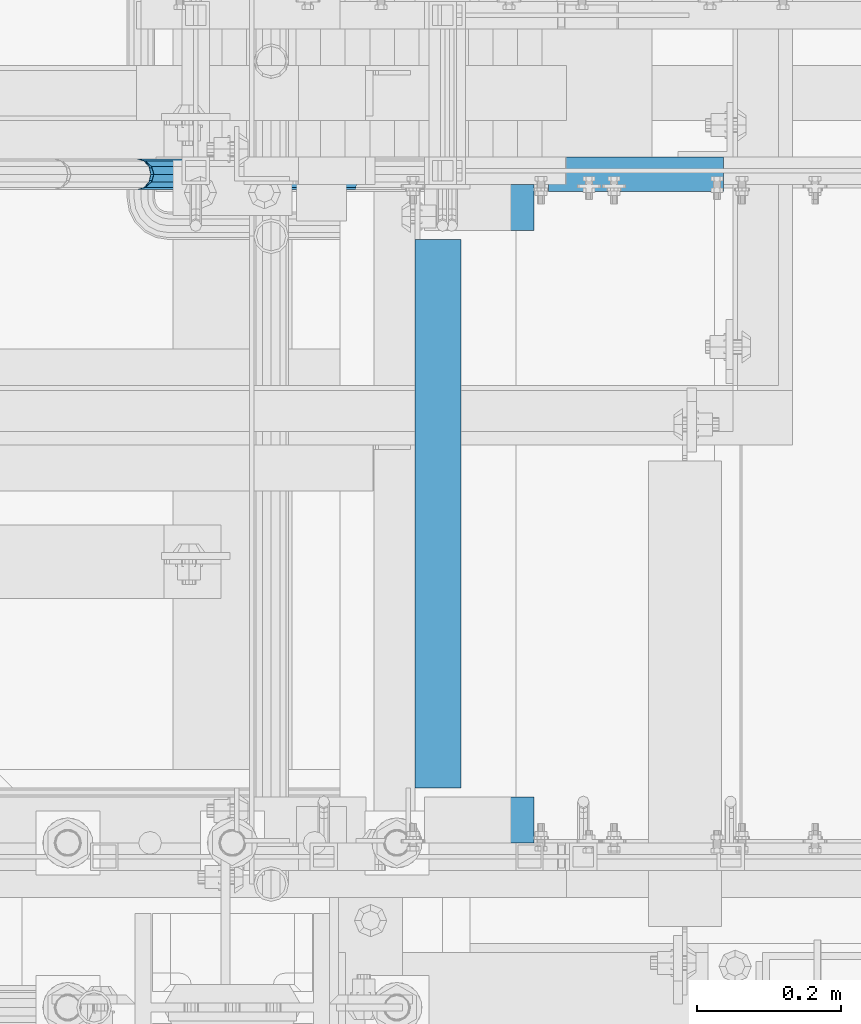
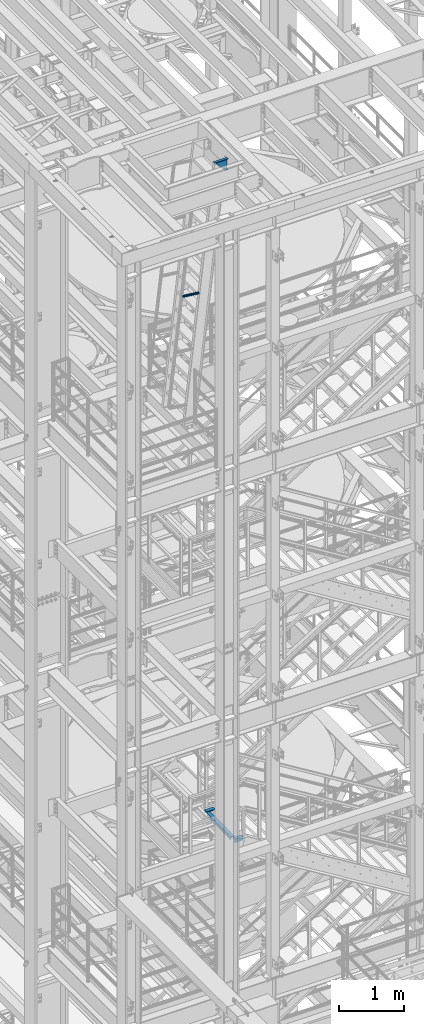
# One storey, part 1134 of 1876: 5 beams, 3 elements without a shape of their own.
"""IFC2X3 building model written with IfcOpenShell, lengths in millimetres."""

from ifc_helpers import new_model, si_unit, frame, origin_with_axes, place, context, subcontext, project, spatial, faceted_brep, material, type_object, element, aggregate, save


model = new_model("IFC2X3")

# Units and contexts
model_context = context("Model", 3, precision=1e-05, world=origin_with_axes())
body_context = subcontext(model_context, "Body", "Model", "MODEL_VIEW")
ifc_project = project(units=[si_unit("LENGTHUNIT", "METRE", prefix="MILLI"), si_unit("AREAUNIT", "SQUARE_METRE"), si_unit("VOLUMEUNIT", "CUBIC_METRE"), si_unit("MASSUNIT", "GRAM", prefix="KILO"), si_unit("TIMEUNIT", "SECOND"), si_unit("PLANEANGLEUNIT", "RADIAN"), si_unit("SOLIDANGLEUNIT", "STERADIAN"), si_unit("THERMODYNAMICTEMPERATUREUNIT", "DEGREE_CELSIUS"), si_unit("LUMINOUSINTENSITYUNIT", "LUMEN")], contexts=[model_context])

# Site, building, storey
site_placement = place(None, origin_with_axes())
site = spatial("IfcSite", under=ifc_project, at=site_placement, CompositionType="ELEMENT")
building_placement = place(site_placement, origin_with_axes())
building = spatial("IfcBuilding", under=site, at=building_placement, Name="Undefined", CompositionType="ELEMENT")
storey_placement = place(building_placement, origin_with_axes())
storey = spatial("IfcBuildingStorey", under=building, at=storey_placement, Name="Undefined", CompositionType="ELEMENT", Elevation=0.0)

# Assembly, beam
assembly_1_placement = place(storey_placement, origin_with_axes())
assembly_1 = element("IfcElementAssembly", 1, at=assembly_1_placement, inside=storey, Name="STRINGER", AssemblyPlace="NOTDEFINED", PredefinedType="RIGID_FRAME")
ifc_material_1 = material(Name="STEEL/A36")
beam_type_1 = type_object("IfcBeamType", Name="L2-1/2X2-1/2X1/4", PredefinedType="NOTDEFINED")
beam_1_placement = place(assembly_1_placement, frame((2012.95000034225, -6045.19999887632, 10702.9249998411), z_axis=(0.0, 0.0, -1.0), x_axis=(0.0, -1.0, 0.0)))
beam_1 = element("IfcBeam", 2, at=beam_1_placement, type_object=beam_type_1, material=ifc_material_1, Name="STRINGER", ObjectType="L2-1/2X2-1/2X1/4", context=body_context, shape_type="Brep", body=[
    faceted_brep([(12.6999938957224, 25.4000000000001, -19.0499992370605), (12.6999938957224, 31.75, -19.0499992370605), (0.0, 31.75, -19.0499992370605), (0.0, 25.4000000000001, -19.0499992370605), (12.6999938957251, 25.4000000000001, 31.75), (12.6999938957251, 31.75, 31.75), (0.0, 25.3999999999996, -25.3999999999996), (0.0, -31.75, -25.3999999999996), (762.000002272681, -31.75, -25.3999999999996), (762.000002272681, 25.4000000000001, -25.3999999999996), (0.0, -31.75, -31.75), (762.000002272681, -31.75, -31.75), (0.0, 31.75, -31.75), (762.000002272681, 31.75, -31.75), (762.000002272681, 31.75, -19.0499992370587), (762.000002272681, 25.4000000000001, -19.0499992370587), (749.300005324439, 31.75, -19.0499992370587), (749.300005324439, 25.4000000000001, -19.0499992370587), (749.300005324439, 25.4000000000001, 31.75), (749.300005324439, 31.75, 31.75)], [[[0, 1, 2, 3]], [[4, 5, 1, 0]], [[6, 7, 8, 9]], [[7, 10, 11, 8]], [[10, 12, 13, 11]], [[9, 8, 11, 13, 14, 15]], [[15, 14, 16, 17]], [[18, 17, 16, 19]], [[3, 6, 9, 15, 17, 18, 4, 0]], [[12, 10, 7, 6, 3, 2]], [[19, 16, 14, 13, 12, 2, 1, 5]], [[18, 19, 5, 4]]]),
])
aggregate(assembly_1, [beam_1])

# Assembly, beams
assembly_2_placement = place(storey_placement, origin_with_axes())
assembly_2 = element("IfcElementAssembly", 3, at=assembly_2_placement, inside=storey, Name="STRINGER", AssemblyPlace="NOTDEFINED", PredefinedType="RIGID_FRAME")
beam_2_placement = place(assembly_2_placement, frame((1993.90000034225, -6000.74999887558, 10702.9249998411), z_axis=(0.0, -1.0, 0.0), x_axis=(1.0, 0.0, 0.0)))
beam_2 = element("IfcBeam", 4, at=beam_2_placement, type_object=beam_type_1, material=ifc_material_1, Name="ANGLE", ObjectType="L2-1/2X2-1/2X1/4", context=body_context, shape_type="Brep", body=[
    faceted_brep([(0.0, 31.75, -31.75), (0.0, 31.75, 31.75), (152.400073242188, 31.75, 31.75), (152.400073242188, 31.75, -31.75), (0.0, 25.3999999999996, 31.75), (152.400073242188, 25.3999999999996, 31.75), (0.0, 25.3999999999996, -25.3999999999996), (152.400073242188, 25.3999999999996, -25.3999999999996), (0.0, -31.75, -25.3999999999996), (152.400073242188, -31.75, -25.3999999999996), (0.0, -31.75, -31.75), (152.400073242188, -31.75, -31.75)], [[[0, 1, 2, 3]], [[1, 4, 5, 2]], [[4, 6, 7, 5]], [[6, 8, 9, 7]], [[8, 10, 11, 9]], [[10, 0, 3, 11]], [[5, 7, 9, 11, 3, 2]], [[10, 8, 6, 4, 1, 0]]]),
])
beam_3_placement = place(assembly_2_placement, frame((2146.3, -6851.65000114826, 10702.925), z_axis=(0.0, 1.0, 0.0), x_axis=(-1.0, 0.0, 0.0)))
beam_3 = element("IfcBeam", 5, at=beam_3_placement, type_object=beam_type_1, material=ifc_material_1, Name="ANGLE", ObjectType="L2-1/2X2-1/2X1/4", context=body_context, shape_type="Brep", body=[
    faceted_brep([(0.0, 31.75, -31.75), (0.0, 31.75, 31.75), (152.400073242188, 31.75, 31.75), (152.400073242188, 31.75, -31.75), (0.0, 25.3999999999996, 31.75), (152.400073242188, 25.3999999999996, 31.75), (0.0, 25.3999999999996, -25.3999999999996), (152.400073242188, 25.3999999999996, -25.3999999999996), (0.0, -31.75, -25.3999999999996), (152.400073242188, -31.75, -25.3999999999996), (0.0, -31.75, -31.75), (152.400073242188, -31.75, -31.75)], [[[0, 1, 2, 3]], [[1, 4, 5, 2]], [[4, 6, 7, 5]], [[6, 8, 9, 7]], [[8, 10, 11, 9]], [[10, 0, 3, 11]], [[5, 7, 9, 11, 3, 2]], [[10, 8, 6, 4, 1, 0]]]),
])
aggregate(assembly_2, [beam_2, beam_3])

assembly_3_placement = place(storey_placement, origin_with_axes())
assembly_3 = element("IfcElementAssembly", 6, at=assembly_3_placement, inside=storey, Name="RIGHT STRINGER", AssemblyPlace="NOTDEFINED", PredefinedType="RIGID_FRAME")
ifc_material_2 = material()
beam_type_2 = type_object("IfcBeamType", Name="PIPE1-1/4SCH40", PredefinedType="NOTDEFINED")
beam_4_placement = place(assembly_3_placement, frame((1595.07828079681, -5954.7125, 20451.6060979218), z_axis=(0.0, 1.0, 0.0), x_axis=(0.993502247476981, 0.0, -0.113812496054638)))
beam_4 = element("IfcBeam", 7, at=beam_4_placement, type_object=beam_type_2, material=ifc_material_2, Name="POST", ObjectType="PIPE1-1/4SCH40", context=body_context, shape_type="Brep", body=[
    faceted_brep([(0.0, 0.0, 21.0820000000003), (10.5410047402225, 10.5410000000047, 18.2575475625836), (10.5410000000002, -10.5410000000002, 18.2575475625836), (10.5410000000002, -10.5410000000002, -18.2575475625836), (10.5410047402225, 10.5410000000047, -18.2575475625836), (-4.28826751885936e-09, 0.0, -21.0820000000003), (18.2575475625836, -18.2575475625836, -10.5409999999993), (18.2575523716411, -13.3999612267653, -10.5410000000002), (13.6205911385651, -8.76300000002811, -15.1779612267264), (11.2725523401174, -1.09139364212751e-11, -17.5259999999998), (13.6205910882173, 8.76299999999537, -15.1779612267264), (18.2575522945893, 13.3999612267216, -10.5410000000002), (18.2575522806238, 18.2575475625817, -10.5410000000002), (21.0819999957121, 17.5259999907203, 0.0), (21.081999995713, 21.0819999907208, 0.0), (18.7339659606611, 15.1779612267237, -8.76299999999992), (18.7339659606627, 15.1779612267237, 8.76299999999992), (18.2575522945893, 13.3999612267216, 10.5410000000002), (18.2575522806238, 18.2575475625817, 10.5410000000002), (13.6205910882217, 8.76299999999537, 15.1779612267264), (11.2725523401217, -1.09139364212751e-11, 17.5259999999998), (13.6205911385692, -8.76300000002811, 15.1779612267264), (18.2575523716411, -13.3999612267653, 10.5410000000002), (18.2575475625836, -18.2575475625836, 10.5409999999993), (18.7339660478675, -15.177961226771, 8.76299999999992), (21.0819999957121, -17.5260000092794, 0.0), (21.0819999957121, -21.0820000092799, 0.0), (18.7339660478659, -15.177961226771, -8.76299999999992), (304.800009609033, -10.5410000004813, -18.2575475625836), (304.800009609034, -18.2575475630765, -10.5410000000002), (304.800009609031, -4.69299266114831e-10, -21.0820000000003), (304.800009609029, 10.5409999995427, -18.2575475625836), (304.800009609028, 18.2575475621416, -10.5410000000002), (304.800009609028, 21.0819999995583, 0.0), (304.800009609028, 18.2575475621416, 10.5410000000002), (304.800009609029, 10.5409999995427, 18.2575475625836), (304.800009609031, -4.69299266114831e-10, 21.0820000000003), (304.800009609033, -10.5410000004813, 18.2575475625836), (304.800009609034, -18.2575475630765, 10.5410000000002), (304.800009609035, -21.0820000004969, 0.0), (304.800009609033, -8.76300000047922, 15.1779612267264), (304.800009609031, -4.69299266114831e-10, 17.5259999999998), (304.800009609029, 8.76299999954426, 15.1779612267264), (304.800009609029, 15.1779612262762, 8.76299999999992), (304.800009609028, 17.5259999995542, 0.0), (304.800009609029, 15.1779612262762, -8.76299999999992), (304.800009609029, 8.76299999954426, -15.1779612267264), (304.800009609031, -4.69299266114831e-10, -17.5259999999998), (304.800009609033, -8.76300000047922, -15.1779612267264), (304.800009609034, -15.1779612272148, -8.76299999999992), (304.800009609034, -17.5260000004928, 0.0), (304.800009609034, -15.1779612272148, 8.76299999999992)], [[[0, 1, 2]], [[3, 4, 5]], [[6, 7, 8, 9, 10, 11, 12, 4, 3]], [[13, 14, 12, 11, 15]], [[16, 17, 18, 14, 13]], [[2, 1, 18, 17, 19, 20, 21, 22, 23]], [[23, 22, 24, 25, 26]], [[26, 25, 27, 7, 6]], [[28, 29, 6, 3]], [[30, 28, 3, 5]], [[31, 30, 5, 4]], [[32, 31, 4, 12]], [[33, 32, 12, 14]], [[34, 33, 14, 18]], [[35, 34, 18, 1]], [[36, 35, 1, 0]], [[37, 36, 0, 2]], [[38, 37, 2, 23]], [[39, 38, 23, 26]], [[29, 39, 26, 6]], [[28, 30, 31, 32, 33, 34, 35, 36, 37, 38, 39, 29], [40, 41, 42, 43, 44, 45, 46, 47, 48, 49, 50, 51]], [[51, 50, 25, 24]], [[21, 40, 51, 24, 22]], [[41, 40, 21, 20]], [[42, 41, 20, 19]], [[43, 42, 19, 17, 16]], [[44, 43, 16, 13]], [[45, 44, 13, 15]], [[10, 46, 45, 15, 11]], [[47, 46, 10, 9]], [[48, 47, 9, 8]], [[49, 48, 8, 7, 27]], [[50, 49, 27, 25]]]),
])
beam_type_3 = type_object("IfcBeamType", Name="MC8X8.5", PredefinedType="NOTDEFINED")
beam_5_placement = place(assembly_3_placement, frame((2409.17125151562, -5954.7125, 22656.8), z_axis=(0.0, 0.0, -1.0), x_axis=(-1.0, 0.0, 0.0)))
beam_5 = element("IfcBeam", 8, at=beam_5_placement, type_object=beam_type_3, material=ifc_material_1, Name="LADDER", ObjectType="MC8X8.5", context=body_context, shape_type="Brep", body=[
    faceted_brep([(9.9464159575291e-08, 23.8125, -101.599999999999), (0.0, 23.8125, 101.599999999999), (61.8026659475058, 23.8125, 101.599999999999), (243.053623451269, 23.8125, -101.599999999999), (0.0, -23.8125, 101.599999999999), (61.8026659475058, -23.8125, 101.599999999999), (0.0, -23.8125, 94.1363687500016), (68.4600985743523, -23.8125, 94.1363687500016), (0.0, 19.0500000000002, 93.2834049999983), (69.2209277885186, 19.0500000000002, 93.2834049999983), (0.0, 19.0500000000002, -93.2834049999983), (235.635361510792, 19.0500000000002, -93.2834049999983), (0.0, -23.8125, -94.1363687500016), (236.396190724959, -23.8125, -94.1363687500016), (9.9464159575291e-08, -23.8125, -101.599999999999), (243.053623451269, -23.8125, -101.599999999999)], [[[0, 1, 2, 3]], [[1, 4, 5, 2]], [[4, 6, 7, 5]], [[6, 8, 9, 7]], [[8, 10, 11, 9]], [[10, 12, 13, 11]], [[12, 14, 15, 13]], [[14, 0, 3, 15]], [[5, 7, 9, 11, 13, 15, 3, 2]], [[14, 12, 10, 8, 6, 4, 1, 0]]]),
])
aggregate(assembly_3, [beam_4, beam_5])

save(model, "model.ifc")
